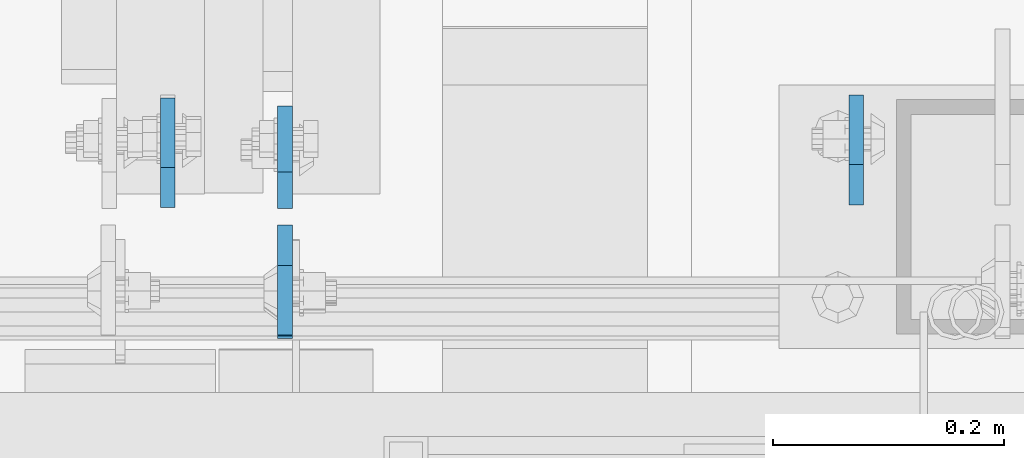
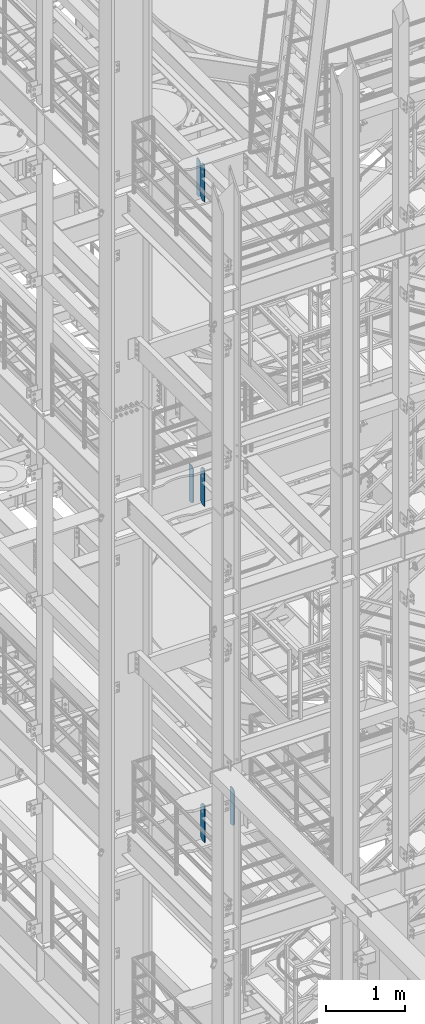
# One storey, part 1466 of 1876: 6 plates, 3 elements without a shape of their own.
"""IFC2X3 building model written with IfcOpenShell, lengths in millimetres."""

from ifc_helpers import new_model, si_unit, frame, origin_with_axes, place, context, subcontext, project, spatial, faceted_brep, material, type_object, element, aggregate, save


model = new_model("IFC2X3")

# Units and contexts
model_context = context("Model", 3, precision=1e-05, world=origin_with_axes())
body_context = subcontext(model_context, "Body", "Model", "MODEL_VIEW")
ifc_project = project(units=[si_unit("LENGTHUNIT", "METRE", prefix="MILLI"), si_unit("AREAUNIT", "SQUARE_METRE"), si_unit("VOLUMEUNIT", "CUBIC_METRE"), si_unit("MASSUNIT", "GRAM", prefix="KILO"), si_unit("TIMEUNIT", "SECOND"), si_unit("PLANEANGLEUNIT", "RADIAN"), si_unit("SOLIDANGLEUNIT", "STERADIAN"), si_unit("THERMODYNAMICTEMPERATUREUNIT", "DEGREE_CELSIUS"), si_unit("LUMINOUSINTENSITYUNIT", "LUMEN")], contexts=[model_context])

# Site, building, storey
site_placement = place(None, origin_with_axes())
site = spatial("IfcSite", under=ifc_project, at=site_placement, CompositionType="ELEMENT")
building_placement = place(site_placement, origin_with_axes())
building = spatial("IfcBuilding", under=site, at=building_placement, Name="Undefined", CompositionType="ELEMENT")
storey_placement = place(building_placement, origin_with_axes())
storey = spatial("IfcBuildingStorey", under=building, at=storey_placement, Name="Undefined", CompositionType="ELEMENT", Elevation=0.0)

# Assembly, plate
assembly_1_placement = place(storey_placement, origin_with_axes())
assembly_1 = element("IfcElementAssembly", 1, at=assembly_1_placement, inside=storey, Name="BEAM", AssemblyPlace="NOTDEFINED", PredefinedType="RIGID_FRAME")
ifc_material = material(Name="STEEL/A36")
plate_type_1 = type_object("IfcPlateType", PredefinedType="NOTDEFINED")
plate_1_placement = place(assembly_1_placement, frame((1095.37500024689, -4564.85625, 17386.3), z_axis=(0.0, 0.0, 1.0), x_axis=(0.0, 1.0, 0.0)))
plate_1 = element("IfcPlate", 2, at=plate_1_placement, type_object=plate_type_1, material=ifc_material, Name="PLATE", context=body_context, shape_type="Brep", body=[
    faceted_brep([(0.0, -6.34999999999991, 31.75), (0.0, -6.34999999999991, 539.75), (0.0, 6.34999999999991, 539.75), (0.0, 6.34999999999991, 31.75), (31.75, -6.34999999999991, 571.5), (31.75, 6.34999999999991, 571.5), (88.9000015258789, -6.34999999999991, 571.5), (88.9000015258789, 6.34999999999991, 571.5), (88.9000015258789, -6.34999999999991, 0.0), (88.9000015258789, 6.34999999999991, 0.0), (31.75, -6.34999999999991, 0.0), (31.75, 6.34999999999991, 0.0)], [[[0, 1, 2, 3]], [[1, 4, 5, 2]], [[4, 6, 7, 5]], [[6, 8, 9, 7]], [[8, 10, 11, 9]], [[10, 0, 3, 11]], [[5, 7, 9, 11, 3, 2]], [[10, 8, 6, 4, 1, 0]]]),
])

assembly_2_placement = place(storey_placement, origin_with_axes())
assembly_2 = element("IfcElementAssembly", 3, at=assembly_2_placement, inside=storey, Name="BEAM", AssemblyPlace="NOTDEFINED", PredefinedType="RIGID_FRAME")
plate_type_2 = type_object("IfcPlateType", PredefinedType="NOTDEFINED")
plate_2_placement = place(assembly_2_placement, frame((1590.67499990463, -4561.68125, 7543.8), z_axis=(0.0, 0.0, 1.0), x_axis=(0.0, 1.0, 0.0)))
plate_2 = element("IfcPlate", 4, at=plate_2_placement, type_object=plate_type_2, material=ifc_material, Name="PLATE", context=body_context, shape_type="Brep", body=[
    faceted_brep([(0.0, -6.34999999999991, 34.9249992370605), (0.0, -6.35000000000036, 538.162475585938), (0.0, 6.35000000000036, 538.162475585938), (0.0, 6.34999999999991, 34.9249992370605), (34.9249992370605, -6.34999999999991, 573.087524414062), (34.9249992370605, 6.34999999999991, 573.087524414062), (95.25, -6.34999999999991, 573.087524414062), (95.25, 6.34999999999991, 573.087524414062), (95.25, -6.35000000000036, 0.0), (95.25, 6.35000000000036, 0.0), (34.9249992370605, -6.34999999999991, 0.0), (34.9249992370605, 6.34999999999991, 0.0)], [[[0, 1, 2, 3]], [[1, 4, 5, 2]], [[4, 6, 7, 5]], [[6, 8, 9, 7]], [[8, 10, 11, 9]], [[10, 0, 3, 11]], [[5, 7, 9, 11, 3, 2]], [[10, 8, 6, 4, 1, 0]]]),
])

# Plate
plate_3_placement = place(assembly_1_placement, frame((1095.37500034226, -4579.14375, 17387.8875), z_axis=(0.0, 0.0, 1.0), x_axis=(0.0, -1.0, 0.0)))
plate_3 = element("IfcPlate", 5, at=plate_3_placement, type_object=plate_type_2, material=ifc_material, Name="PLATE", context=body_context, shape_type="Brep", body=[
    faceted_brep([(0.0, -6.34999999999991, 34.9249992370605), (0.0, -6.34999999999991, 534.987476348877), (0.0, 6.34999999999991, 534.987476348877), (0.0, 6.34999999999991, 34.9249992370605), (34.9249992370605, -6.34999999999991, 569.912475585938), (34.9249992370605, 6.34999999999991, 569.912475585938), (95.25, -6.35000000000036, 569.912475585938), (95.25, 6.35000000000036, 569.912475585938), (95.25, -6.35000000000036, 0.0), (95.25, 6.35000000000036, 0.0), (34.9249992370605, -6.34999999999991, 0.0), (34.9249992370605, 6.34999999999991, 0.0)], [[[0, 1, 2, 3]], [[1, 4, 5, 2]], [[4, 6, 7, 5]], [[6, 8, 9, 7]], [[8, 10, 11, 9]], [[10, 0, 3, 11]], [[5, 7, 9, 11, 3, 2]], [[10, 8, 6, 4, 1, 0]]]),
])

aggregate(assembly_1, [plate_1, plate_3])

# Assembly, plate
assembly_3_placement = place(storey_placement, origin_with_axes())
assembly_3 = element("IfcElementAssembly", 6, at=assembly_3_placement, inside=storey, Name="BEAM", AssemblyPlace="NOTDEFINED", PredefinedType="RIGID_FRAME")
plate_4_placement = place(assembly_3_placement, frame((1095.3750002286, -4579.9375, 12709.525), z_axis=(0.0, 0.0, 1.0), x_axis=(0.0, -1.0, 0.0)))
plate_4 = element("IfcPlate", 7, at=plate_4_placement, type_object=plate_type_2, material=ifc_material, Name="PLATE", context=body_context, shape_type="Brep", body=[
    faceted_brep([(0.0, -6.34999999999991, 34.9249992370605), (0.0, -6.35000000000036, 538.162475585938), (0.0, 6.35000000000036, 538.162475585938), (0.0, 6.34999999999991, 34.9249992370605), (34.9249992370605, -6.34999999999991, 573.087524414062), (34.9249992370605, 6.34999999999991, 573.087524414062), (95.25, -6.34999999999991, 573.087524414062), (95.25, 6.34999999999991, 573.087524414062), (95.25, -6.35000000000036, 0.0), (95.25, 6.35000000000036, 0.0), (34.9249992370605, -6.34999999999991, 0.0), (34.9249992370605, 6.34999999999991, 0.0)], [[[0, 1, 2, 3]], [[1, 4, 5, 2]], [[4, 6, 7, 5]], [[6, 8, 9, 7]], [[8, 10, 11, 9]], [[10, 0, 3, 11]], [[5, 7, 9, 11, 3, 2]], [[10, 8, 6, 4, 1, 0]]]),
])

# Plate
plate_5_placement = place(assembly_2_placement, frame((1095.37500024689, -4582.31875, 7543.8), z_axis=(0.0, 0.0, 1.0), x_axis=(0.0, -1.0, 0.0)))
plate_5 = element("IfcPlate", 8, at=plate_5_placement, type_object=plate_type_2, material=ifc_material, Name="PLATE", context=body_context, shape_type="Brep", body=[
    faceted_brep([(0.0, -6.34999999999991, 34.9249992370605), (0.0, -6.35000000000036, 538.162475585938), (0.0, 6.35000000000036, 538.162475585938), (0.0, 6.34999999999991, 34.9249992370605), (34.9249992370605, -6.34999999999991, 573.087524414062), (34.9249992370605, 6.34999999999991, 573.087524414062), (95.25, -6.34999999999991, 573.087524414062), (95.25, 6.34999999999991, 573.087524414062), (95.25, -6.35000000000036, 0.0), (95.25, 6.35000000000036, 0.0), (34.9249992370605, -6.34999999999991, 0.0), (34.9249992370605, 6.34999999999991, 0.0)], [[[0, 1, 2, 3]], [[1, 4, 5, 2]], [[4, 6, 7, 5]], [[6, 8, 9, 7]], [[8, 10, 11, 9]], [[10, 0, 3, 11]], [[5, 7, 9, 11, 3, 2]], [[10, 8, 6, 4, 1, 0]]]),
])

aggregate(assembly_2, [plate_2, plate_5])

plate_6_placement = place(assembly_3_placement, frame((993.775, -4564.0625, 12709.525), z_axis=(0.0, 0.0, 1.0), x_axis=(0.0, 1.0, 0.0)))
plate_6 = element("IfcPlate", 9, at=plate_6_placement, type_object=plate_type_2, material=ifc_material, Name="PLATE", context=body_context, shape_type="Brep", body=[
    faceted_brep([(0.0, -6.34999999999991, 34.9249992370605), (0.0, -6.35000000000036, 538.162475585938), (0.0, 6.35000000000036, 538.162475585938), (0.0, 6.34999999999991, 34.9249992370605), (34.9249992370605, -6.34999999999991, 573.087524414062), (34.9249992370605, 6.34999999999991, 573.087524414062), (95.25, -6.34999999999991, 573.087524414062), (95.25, 6.34999999999991, 573.087524414062), (95.25, -6.35000000000036, 0.0), (95.25, 6.35000000000036, 0.0), (34.9249992370605, -6.34999999999991, 0.0), (34.9249992370605, 6.34999999999991, 0.0)], [[[0, 1, 2, 3]], [[1, 4, 5, 2]], [[4, 6, 7, 5]], [[6, 8, 9, 7]], [[8, 10, 11, 9]], [[10, 0, 3, 11]], [[5, 7, 9, 11, 3, 2]], [[10, 8, 6, 4, 1, 0]]]),
])

aggregate(assembly_3, [plate_4, plate_6])

save(model, "model.ifc")
